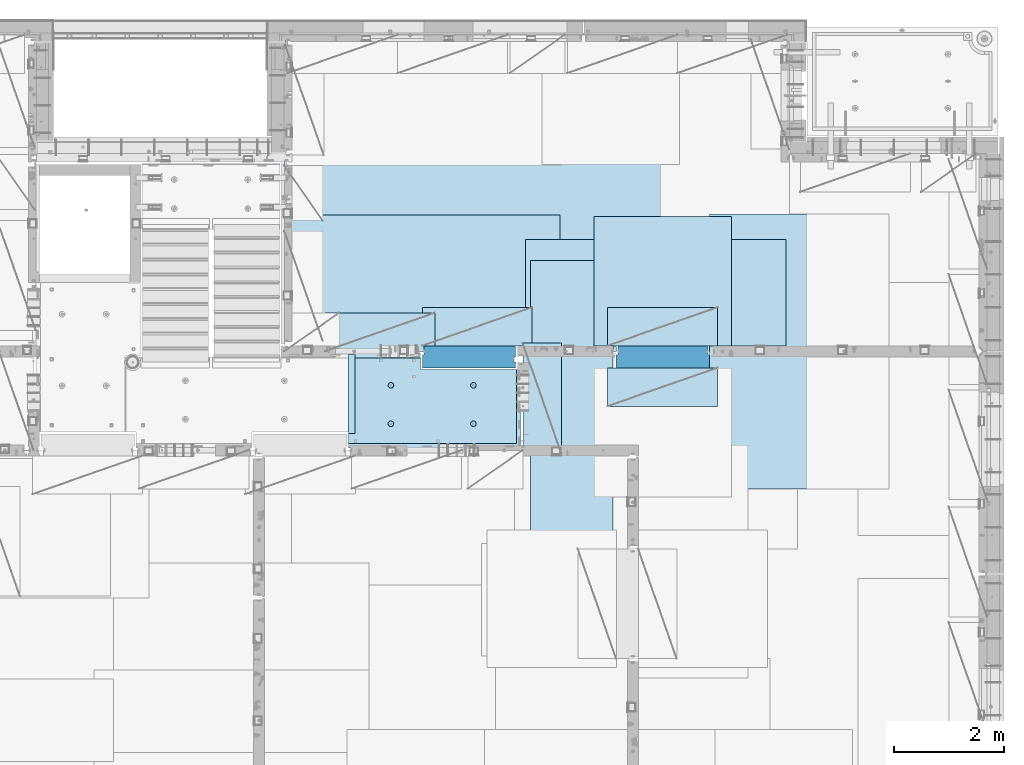
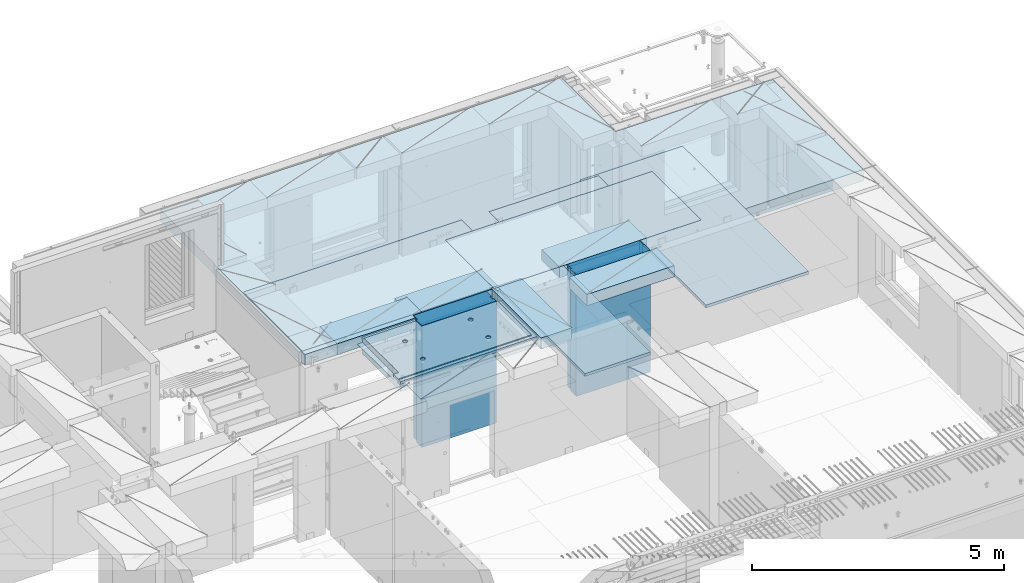
# One storey, part 210 of 350: 12 plates, 2 slabs, 13 elements without a shape of their own.
"""IFC2X3 building model written with IfcOpenShell, lengths in millimetres."""

from ifc_helpers import new_model, si_unit, frame, origin_with_axes, place, context, subcontext, project, spatial, faceted_brep, material, type_object, element, aggregate, save


model = new_model("IFC2X3")

# Units and contexts
model_context = context("Model", 3, precision=1e-05, world=origin_with_axes())
body_context = subcontext(model_context, "Body", "Model", "MODEL_VIEW")
ifc_project = project(units=[si_unit("LENGTHUNIT", "METRE", prefix="MILLI"), si_unit("AREAUNIT", "SQUARE_METRE"), si_unit("VOLUMEUNIT", "CUBIC_METRE"), si_unit("MASSUNIT", "GRAM", prefix="KILO"), si_unit("TIMEUNIT", "SECOND"), si_unit("PLANEANGLEUNIT", "RADIAN"), si_unit("SOLIDANGLEUNIT", "STERADIAN"), si_unit("THERMODYNAMICTEMPERATUREUNIT", "DEGREE_CELSIUS"), si_unit("LUMINOUSINTENSITYUNIT", "LUMEN")], contexts=[model_context])

# Site, building, storey
site_placement = place(None, origin_with_axes())
site = spatial("IfcSite", under=ifc_project, at=site_placement, CompositionType="ELEMENT")
building_placement = place(site_placement, origin_with_axes())
building = spatial("IfcBuilding", under=site, at=building_placement, CompositionType="ELEMENT")
storey_placement = place(building_placement, origin_with_axes())
storey = spatial("IfcBuildingStorey", under=building, at=storey_placement, Name="2", CompositionType="ELEMENT", Elevation=0.0)

# Assembly, slab
assembly_1_placement = place(storey_placement, origin_with_axes())
assembly_1 = element("IfcElementAssembly", 1, at=assembly_1_placement, inside=storey, AssemblyPlace="NOTDEFINED", PredefinedType="REINFORCEMENT_UNIT")
ifc_material_1 = material(Name="CONCRETE/C25/30")
slab_type_1 = type_object("IfcSlabType", PredefinedType="NOTDEFINED")
slab_1_placement = place(assembly_1_placement, frame((26570.0059390845, 15220.0026483125, 87620.0), z_axis=(-0.999999999997437, -2.26400000064461e-06, 0.0), x_axis=(-1.19799915409591e-06, 0.999999999999282, 0.0)))
slab_1 = element("IfcSlab", 2, at=slab_1_placement, type_object=slab_type_1, material=ifc_material_1, PredefinedType="FLOOR", context=body_context, shape_type="Brep", body=[
    faceted_brep([(260.000036693442, 30.0, 20.0001116859203), (260.00040878505, 30.0, 210.00282380305), (760.000392750888, 30.0, 210.001882803081), (760.000035167954, 30.0, 20.0003241859195), (259.999997532928, 50.0008466322761, 0.000110715616756352), (259.999997531775, 130.0, 4.72937244921923e-11), (260.00040878505, 130.0, 210.00282380305), (260.00003669344, 50.0008466322906, 20.0001116859239), (760.000392750888, 130.0, 210.001882803081), (759.999997530887, 50.0009701322706, 0.00188280345173553), (760.000035167954, 50.0009701322851, 20.0003241859267), (759.999997530887, 130.0, 1.4915713109076e-10), (0.0, 130.0, -1.81898940354586e-12), (0.0, 50.0007830199902, -3.63797880709171e-12), (2.23492861550767e-06, 50.0007830199902, 20.0000012144774), (0.00314200731554592, 50.0009709416772, 1679.99820316408), (0.00316042736994859, 130.0, 1679.99820316404), (20.0042037197236, 50.0007871208509, 20.0000019346335), (20.0050448999082, 50.0009732451872, 1679.9981655205), (20.0051981998968, 30.0, 1979.99816552074), (210.003723882246, 30.0, 1979.99780794351), (210.003159282247, 30.0, 1679.99780794404), (20.0050448999027, 30.0, 1679.9981655205), (20.0057858500695, 50.0011356208415, 3129.99855788155), (0.00588817475545511, 50.0011356208415, 3129.99536132812), (0.00371018100122456, 50.0010050132987, 1979.99820316354), (20.0051981998986, 50.0010068401461, 1979.99816552074), (1720.00727399273, -49.9988643791585, 3014.99216831216), (1700.0058891816, -49.9988643791585, 3014.99217713277), (1700.0058891816, 9.99999999994179, 3014.99217713277), (270.007273993393, 9.99999999994179, 3014.99280776216), (270.007273993393, -130.000000000058, 3014.99280776216), (1640.00591170533, -130.000000000058, 3014.99220359276), (1640.00591170533, -110.000000000058, 3014.99220359276), (1720.00727399273, -110.000000000058, 3014.99216831216), (1700.00578510373, 9.99999999994179, 3129.99536132812), (270.007324709519, 9.99999999994179, 3129.99536132812), (1700.00588013352, 9.99999999994179, 3024.99005271558), (270.007324709519, -130.0, 3129.99536132812), (0.0, -49.9992169800098, -3.63797880709171e-12), (1.81898940354586e-12, -110.000000000058, 0.0), (0.00588817475545511, -110.0, 3129.99536132812), (0.00588817475545511, -49.9988643791585, 3129.99536132812), (2.27349282795331e-05, -49.9992169800098, 20.000001214441), (40.0000000237706, -110.0, 0.00323799208854325), (40.0000056179106, -110.0, 80.000116817555), (80.0001648500238, -110.0, 80.0001140175445), (80.0058896111077, -110.0, 3129.99536132811), (80.0001648500238, -130.0, 80.0001140175445), (80.0058896111077, -130.0, 3129.99536132812), (458.262860973307, -110.000000000015, 813.90255309167), (472.201273869185, -110.000000000015, 821.004529187678), (483.262860973307, -110.000000000015, 832.066116291804), (490.364837069317, -110.000000000015, 846.004529187678), (492.812011254558, -110.000000000015, 861.455378906427), (490.364837069317, -110.000000000015, 876.906228625172), (483.262860973307, -110.000000000015, 890.844641521049), (472.201273869185, -110.000000000015, 901.906228625176), (458.262860973306, -110.000000000015, 909.008204721184), (442.81201125456, -110.000000000015, 911.455378906427), (427.361161535811, -110.000000000015, 909.008204721184), (413.422748639936, -110.000000000015, 901.906228625176), (402.361161535813, -110.000000000015, 890.844641521046), (395.259185439802, -110.000000000015, 876.906228625176), (392.81201125456, -110.000000000015, 861.455378906427), (395.259185439802, -110.000000000015, 846.004529187681), (402.361161535813, -110.000000000015, 832.0661162918), (413.422748639936, -110.000000000015, 821.004529187678), (427.361161535813, -110.000000000015, 813.90255309167), (442.812011254558, -110.000000000015, 811.455378906427), (458.965172324157, -130.0, 811.741061009179), (442.812011254558, -130.0, 809.182651633699), (473.537149442574, -130.0, 819.165854200462), (485.101535960521, -130.0, 830.730240718414), (492.526329151806, -130.0, 845.302217836826), (495.084738527285, -130.0, 861.45537890643), (492.526329151804, -130.0, 877.608539976027), (485.101535960521, -130.0, 892.180517094443), (473.537149442574, -130.0, 903.744903612387), (458.965172324157, -130.0, 911.16969680367), (442.81201125456, -130.0, 913.728106179151), (426.658850184962, -130.0, 911.169696803674), (412.086873066544, -130.0, 903.744903612391), (400.522486548598, -130.0, 892.180517094443), (393.097693357315, -130.0, 877.608539976027), (390.539283981834, -130.0, 861.455378906427), (393.097693357317, -130.0, 845.302217836826), (400.522486548598, -130.0, 830.730240718414), (412.086873066544, -130.0, 819.165854200462), (426.658850184962, -130.0, 811.741061009183), (1158.26361347154, -110.000000000058, 2313.90608356011), (1172.20202636741, -110.000000000058, 2321.00805965612), (1183.26361347154, -110.000000000058, 2332.06964676024), (1190.36558956755, -110.000000000058, 2346.00805965611), (1192.81276375279, -110.000000000058, 2361.45890937486), (1190.36558956755, -110.000000000058, 2376.90975909361), (1183.26361347154, -110.000000000058, 2390.84817198949), (1172.20202636741, -110.000000000058, 2401.90975909361), (1158.26361347154, -110.000000000058, 2409.01173518962), (1142.81276375279, -110.000000000058, 2411.45890937487), (1127.36191403404, -110.000000000058, 2409.01173518962), (1113.42350113817, -110.000000000058, 2401.90975909361), (1102.36191403404, -110.000000000058, 2390.84817198948), (1095.25993793803, -110.000000000058, 2376.90975909361), (1092.81276375279, -110.000000000058, 2361.45890937486), (1095.25993793803, -110.000000000058, 2346.00805965612), (1102.36191403404, -110.000000000058, 2332.06964676024), (1113.42350113817, -110.000000000058, 2321.00805965611), (1127.36191403405, -110.000000000058, 2313.90608356011), (1142.81276375279, -110.000000000058, 2311.45890937486), (1158.96592482239, -130.000000000044, 2311.74459147762), (1142.81276375279, -130.000000000044, 2309.18618210214), (1173.5379019408, -130.000000000044, 2319.1693846689), (1185.10228845875, -130.000000000044, 2330.73377118685), (1192.52708165004, -130.000000000044, 2345.30574830526), (1195.08549102551, -130.000000000044, 2361.45890937486), (1192.52708165004, -130.000000000044, 2377.61207044447), (1185.10228845875, -130.000000000044, 2392.18404756288), (1173.5379019408, -130.000000000044, 2403.74843408083), (1158.96592482239, -130.000000000044, 2411.17322727211), (1142.81276375279, -130.000000000044, 2413.73163664759), (1126.65960268319, -130.000000000044, 2411.17322727211), (1112.08762556478, -130.000000000044, 2403.74843408083), (1100.52323904683, -130.000000000044, 2392.18404756287), (1093.09844585554, -130.000000000044, 2377.61207044447), (1090.54003648007, -130.000000000044, 2361.45890937486), (1093.09844585555, -130.000000000044, 2345.30574830526), (1100.52323904683, -130.000000000044, 2330.73377118685), (1112.08762556478, -130.000000000044, 2319.1693846689), (1126.65960268319, -130.000000000044, 2311.74459147762), (1158.26322681425, -110.000000000029, 813.902566246979), (1172.20163971013, -110.000000000029, 821.004542342987), (1183.26322681425, -110.000000000029, 832.066129447114), (1190.36520291026, -110.000000000029, 846.004542342987), (1192.8123770955, -110.000000000029, 861.455392061736), (1190.36520291026, -110.000000000029, 876.906241780482), (1183.26322681425, -110.000000000029, 890.844654676363), (1172.20163971012, -110.000000000029, 901.906241780485), (1158.26322681425, -110.000000000029, 909.008217876493), (1142.8123770955, -110.000000000029, 911.455392061736), (1127.36152737675, -110.000000000029, 909.008217876493), (1113.42311448088, -110.000000000029, 901.906241780485), (1102.36152737675, -110.000000000029, 890.844654676359), (1095.25955128074, -110.000000000029, 876.906241780485), (1092.8123770955, -110.000000000029, 861.45539206174), (1095.25955128074, -110.000000000029, 846.004542342991), (1102.36152737675, -110.000000000029, 832.06612944711), (1113.42311448088, -110.000000000029, 821.004542342987), (1127.36152737675, -110.000000000029, 813.902566246979), (1142.8123770955, -110.000000000029, 811.455392061736), (1158.9655381651, -130.000000000029, 811.741074164489), (1142.8123770955, -130.000000000029, 809.182664789012), (1173.53751528352, -130.000000000029, 819.165867355772), (1185.10190180146, -130.000000000029, 830.730253873724), (1192.52669499275, -130.000000000029, 845.302230992136), (1195.08510436823, -130.000000000029, 861.45539206174), (1192.52669499275, -130.000000000029, 877.608553131337), (1185.10190180146, -130.000000000029, 892.180530249756), (1173.53751528351, -130.000000000029, 903.744916767697), (1158.9655381651, -130.000000000029, 911.16970995898), (1142.8123770955, -130.000000000029, 913.728119334461), (1126.6592160259, -130.000000000029, 911.169709958984), (1112.08723890749, -130.000000000029, 903.7449167677), (1100.52285238954, -130.000000000029, 892.180530249752), (1093.09805919825, -130.000000000029, 877.608553131337), (1090.53964982277, -130.000000000015, 861.455392061736), (1093.09805919826, -130.000000000015, 845.302230992136), (1100.52285238954, -130.000000000015, 830.730253873724), (1112.08723890749, -130.000000000015, 819.165867355776), (1126.6592160259, -130.000000000015, 811.741074164493), (458.263613472778, -110.000000000058, 2313.90740096011), (472.202026368655, -110.000000000058, 2321.00937705611), (483.263613472776, -110.000000000058, 2332.07096416024), (490.365589568788, -110.000000000058, 2346.00937705611), (492.812763754029, -110.000000000058, 2361.46022677486), (490.365589568788, -110.000000000058, 2376.91107649361), (483.263613472778, -110.000000000058, 2390.84948938949), (472.202026368655, -110.000000000058, 2401.91107649361), (458.263613472776, -110.000000000058, 2409.01305258962), (442.812763754029, -110.000000000058, 2411.46022677486), (427.361914035282, -110.000000000058, 2409.01305258962), (413.423501139407, -110.000000000058, 2401.91107649361), (402.361914035284, -110.000000000058, 2390.84948938949), (395.259937939272, -110.000000000058, 2376.91107649361), (392.812763754031, -110.000000000058, 2361.46022677486), (395.259937939272, -110.000000000058, 2346.00937705612), (402.361914035284, -110.000000000058, 2332.07096416024), (413.423501139407, -110.000000000058, 2321.00937705611), (427.361914035284, -110.000000000058, 2313.90740096011), (442.812763754029, -110.000000000058, 2311.46022677486), (458.965924823628, -130.000000000029, 2311.74590887762), (442.812763754029, -130.000000000029, 2309.18749950214), (473.537901942043, -130.000000000029, 2319.1707020689), (485.10228845999, -130.000000000029, 2330.73508858685), (492.527081651273, -130.000000000029, 2345.30706570526), (495.085491026754, -130.000000000029, 2361.46022677486), (492.527081651273, -130.000000000029, 2377.61338784446), (485.102288459992, -130.000000000029, 2392.18536496288), (473.537901942043, -130.000000000029, 2403.74975148082), (458.965924823628, -130.000000000029, 2411.1745446721), (442.812763754031, -130.000000000029, 2413.73295404758), (426.659602684433, -130.000000000029, 2411.17454467211), (412.087625566017, -130.000000000029, 2403.74975148082), (400.523239048071, -130.000000000029, 2392.18536496288), (393.098445856787, -130.000000000029, 2377.61338784446), (390.540036481307, -130.000000000029, 2361.46022677486), (393.098445856789, -130.000000000029, 2345.30706570526), (400.523239048067, -130.000000000029, 2330.73508858685), (412.087625566017, -130.000000000029, 2319.17070206891), (426.659602684433, -130.000000000029, 2311.74590887762), (1640.0069692709, -130.000000000058, 1820.00285259458), (1429.99412576448, -130.0, 80.0005450159842), (1430.00077693619, -130.000000000044, 1820.00324782623), (1640.0069692709, -110.000000000058, 1820.00285259458), (1720.00719314726, -110.000000000058, 1820.00270203416), (1720.00719416424, -49.9988643791585, 1820.00270203415), (1700.00697064704, -49.9988643791585, 1820.00273967458), (1430.00077693619, 129.999999999985, 1820.00324782623), (1720.00507313573, 130.0, 1820.00270203815), (1720.00696350816, 50.0011356208415, 1820.00270203459), (1700.00697064704, 50.0011356208415, 1820.00273967458), (1720.00548380367, 130.0, 2629.9953613439), (1720.00479630696, 50.0011356208415, 2629.99536134425), (1700.00623760369, 50.0011356208415, 2629.99539898154), (1700.00623760369, 30.0, 2629.99539898154), (1700.00578510373, 30.0, 3129.99535793147), (1510.00479630733, 130.0, 2629.99575656425), (1510.00479630733, 30.0, 2629.99575656425), (1510.00573730659, 130.0, 3129.99536132812), (1510.00573730659, 30.0, 3129.99536134176), (0.00588817475545511, 130.0, 3129.99536132812), (20.0057858500695, -49.9988643791585, 3129.99855788155), (0.00372479000361636, 130.0, 1979.99820316351), (210.003723882246, 130.0, 1979.99780794351), (210.003159282247, 130.0, 1679.99780794404), (20.0042037196527, -49.9988643791585, 20.0000019345935), (20.0041864226587, -49.9992128791491, 7.34271452529356e-07), (1429.99419217423, -49.9988643791585, 20.0006089333838), (1429.99420067423, -49.9988643791585, 0.000608933383773547), (80.0000146155362, -110.0, 0.000114017555461032), (1429.99735169022, -110.0, 7.40013310860377e-05), (1429.99412576448, -110.0, 80.0005450159842), (1429.99416747423, 50.0011356208415, 20.0006089334311), (1429.99417597423, 50.0011356208415, 0.000608933431067271), (1429.99735169022, 130.0, 2.80124368146062e-10), (20.0041864225386, 50.0007871208509, -3.03407432511449e-09)], [[[0, 1, 2, 3]], [[4, 5, 6, 1, 0, 7]], [[8, 2, 1, 6]], [[9, 10, 3, 2, 8, 11]], [[12, 13, 14, 15, 16]], [[14, 17, 18, 15]], [[19, 20, 21, 22]], [[23, 24, 25, 26]], [[27, 28, 29, 30, 31, 32, 33, 34]], [[35, 36, 30, 29, 37]], [[31, 30, 36, 38]], [[39, 40, 41, 42, 43]], [[44, 45, 46, 47, 41, 40]], [[48, 49, 47, 46]], [[50, 51, 52, 53, 54, 55, 56, 57, 58, 59, 60, 61, 62, 63, 64, 65, 66, 67, 68, 69]], [[70, 50, 69, 71]], [[72, 51, 50, 70]], [[73, 52, 51, 72]], [[74, 53, 52, 73]], [[75, 54, 53, 74]], [[76, 55, 54, 75]], [[77, 56, 55, 76]], [[78, 57, 56, 77]], [[79, 58, 57, 78]], [[80, 59, 58, 79]], [[81, 60, 59, 80]], [[82, 61, 60, 81]], [[83, 62, 61, 82]], [[84, 63, 62, 83]], [[85, 64, 63, 84]], [[86, 65, 64, 85]], [[87, 66, 65, 86]], [[88, 67, 66, 87]], [[89, 68, 67, 88]], [[71, 69, 68, 89]], [[90, 91, 92, 93, 94, 95, 96, 97, 98, 99, 100, 101, 102, 103, 104, 105, 106, 107, 108, 109]], [[110, 90, 109, 111]], [[112, 91, 90, 110]], [[113, 92, 91, 112]], [[114, 93, 92, 113]], [[115, 94, 93, 114]], [[116, 95, 94, 115]], [[117, 96, 95, 116]], [[118, 97, 96, 117]], [[119, 98, 97, 118]], [[120, 99, 98, 119]], [[121, 100, 99, 120]], [[122, 101, 100, 121]], [[123, 102, 101, 122]], [[124, 103, 102, 123]], [[125, 104, 103, 124]], [[126, 105, 104, 125]], [[127, 106, 105, 126]], [[128, 107, 106, 127]], [[129, 108, 107, 128]], [[111, 109, 108, 129]], [[130, 131, 132, 133, 134, 135, 136, 137, 138, 139, 140, 141, 142, 143, 144, 145, 146, 147, 148, 149]], [[150, 130, 149, 151]], [[152, 131, 130, 150]], [[153, 132, 131, 152]], [[154, 133, 132, 153]], [[155, 134, 133, 154]], [[156, 135, 134, 155]], [[157, 136, 135, 156]], [[158, 137, 136, 157]], [[159, 138, 137, 158]], [[160, 139, 138, 159]], [[161, 140, 139, 160]], [[162, 141, 140, 161]], [[163, 142, 141, 162]], [[164, 143, 142, 163]], [[165, 144, 143, 164]], [[166, 145, 144, 165]], [[167, 146, 145, 166]], [[168, 147, 146, 167]], [[169, 148, 147, 168]], [[151, 149, 148, 169]], [[170, 171, 172, 173, 174, 175, 176, 177, 178, 179, 180, 181, 182, 183, 184, 185, 186, 187, 188, 189]], [[190, 170, 189, 191]], [[192, 171, 170, 190]], [[193, 172, 171, 192]], [[194, 173, 172, 193]], [[195, 174, 173, 194]], [[196, 175, 174, 195]], [[197, 176, 175, 196]], [[198, 177, 176, 197]], [[199, 178, 177, 198]], [[200, 179, 178, 199]], [[201, 180, 179, 200]], [[202, 181, 180, 201]], [[203, 182, 181, 202]], [[204, 183, 182, 203]], [[205, 184, 183, 204]], [[206, 185, 184, 205]], [[207, 186, 185, 206]], [[208, 187, 186, 207]], [[209, 188, 187, 208]], [[191, 189, 188, 209]], [[210, 32, 31, 38, 49, 48, 211, 212], [208, 207, 206, 205, 204, 203, 202, 201, 200, 199, 198, 197, 196, 195, 194, 193, 192, 190, 191, 209], [168, 167, 166, 165, 164, 163, 162, 161, 160, 159, 158, 157, 156, 155, 154, 153, 152, 150, 151, 169], [128, 127, 126, 125, 124, 123, 122, 121, 120, 119, 118, 117, 116, 115, 114, 113, 112, 110, 111, 129], [88, 87, 86, 85, 84, 83, 82, 81, 80, 79, 78, 77, 76, 75, 74, 73, 72, 70, 71, 89]], [[33, 32, 210, 213]], [[34, 33, 213, 214]], [[27, 34, 214, 215]], [[28, 27, 215, 216]], [[214, 213, 210, 212, 217, 218, 219, 220, 216, 215]], [[219, 218, 221, 222]], [[220, 219, 222, 223]], [[35, 37, 29, 28, 216, 220, 223, 224, 225]], [[222, 221, 226, 227, 224, 223]], [[228, 229, 227, 226]], [[224, 227, 229, 225]], [[228, 230, 24, 23, 231, 42, 41, 47, 49, 38, 36, 35, 225, 229]], [[24, 230, 232, 25]], [[233, 20, 19, 26, 25, 232]], [[234, 21, 20, 233]], [[16, 15, 18, 22, 21, 234]], [[17, 235, 231, 23, 26, 19, 22, 18]], [[43, 42, 231, 235]], [[236, 39, 43, 235, 237, 238]], [[239, 44, 40, 39, 236, 238, 240]], [[46, 45, 44, 239, 240, 241]], [[48, 46, 241, 211]], [[240, 238, 237, 242, 243, 244, 217, 212, 211, 241]], [[244, 243, 9, 11]], [[6, 5, 12, 16, 234, 233, 232, 230, 228, 226, 221, 218, 217, 244, 11, 8]], [[245, 13, 12, 5, 4]], [[17, 14, 13, 245, 4, 7]], [[242, 237, 235, 17, 7, 0, 3, 10]], [[243, 242, 10, 9]]]),
])
aggregate(assembly_1, [slab_1])

assembly_2_placement = place(storey_placement, origin_with_axes())
assembly_2 = element("IfcElementAssembly", 3, at=assembly_2_placement, inside=storey, AssemblyPlace="NOTDEFINED", PredefinedType="REINFORCEMENT_UNIT")
ifc_material_2 = material(Name="CONCRETE/C30/37")
slab_type_2 = type_object("IfcSlabType", PredefinedType="NOTDEFINED")
slab_2_placement = place(assembly_2_placement, frame((22310.0, 16980.0, 87595.0), z_axis=(0.0, 1.0, 0.0), x_axis=(1.0, 0.0, 0.0)))
slab_2 = element("IfcSlab", 4, at=slab_2_placement, type_object=slab_type_2, material=ifc_material_2, PredefinedType="FLOOR", context=body_context, shape_type="Brep", body=[
    faceted_brep([(4369.99914550782, -135.0, 99.9999987875526), (4369.99914550782, 135.0, 99.9999987875526), (4369.99914550782, 135.0, 0.0), (4369.99914550782, -135.0, 0.0), (4169.99914550781, -135.0, 99.9997253417969), (4169.99914550781, 135.0, 99.9997253417969), (2489.99914550781, -135.0, 0.0), (2489.99914550781, 135.0, 0.0), (2489.99914550781, 135.0, 99.9997253417969), (2489.99914550781, -135.0, 99.9997253417969), (1.81898940354586e-12, -135.0, 1.81898940354586e-12), (1.81898940354586e-12, 135.0, 1.81898940354586e-12), (-39.9985427856445, -135.0, -0.0037095642182976), (-39.9985427856445, 135.0, -0.0037095642182976), (-40.0, -135.0, 3600.00048828125), (-40.0, 135.0, 3600.00048828125), (-20.0, -135.0, 3600.0), (-20.0, 135.0, 3600.0), (-20.0, -135.0, 5760.0), (-20.0, 135.0, 5760.0), (9149.9990234375, -135.0, 5760.0), (9149.9990234375, 135.0, 5760.0), (9149.9990234375, -135.0, 3600.00073242188), (9149.9990234375, 135.0, 3600.00073242188), (12750.0, -135.0, 3599.9951171875), (12750.0, 135.0, 3599.9951171875), (12750.0, -135.0, 0.0), (12750.0, 135.0, 0.0), (7685.0006429507, -135.0, 0.0), (7685.0006429507, 135.0, 0.0), (7685.0006429507, -135.0, 99.9996630941932), (7685.0006429507, 135.0, 99.9996630941932), (5999.99954431789, -135.0, 99.9996630941932), (5999.99954431789, 135.0, 99.9996630941932), (5999.99954431789, -135.0, 0.0), (5999.99954431789, 135.0, 0.0), (2730.00000000001, 135.0, 99.9997253417969), (2730.00000000001, -135.0, 99.9997253417969)], [[[0, 1, 2, 3]], [[4, 5, 1, 0]], [[6, 7, 8, 9]], [[10, 11, 7, 6]], [[10, 12, 13, 11]], [[12, 14, 15, 13]], [[14, 16, 17, 15]], [[16, 18, 19, 17]], [[18, 20, 21, 19]], [[20, 22, 23, 21]], [[22, 24, 25, 23]], [[24, 26, 27, 25]], [[27, 26, 28, 29]], [[30, 31, 29, 28]], [[32, 33, 31, 30]], [[34, 35, 33, 32]], [[35, 34, 3, 2]], [[36, 8, 7, 11, 13, 15, 17, 19, 21, 23, 25, 27, 29, 31, 33, 35, 2, 1, 5]], [[37, 9, 8, 36, 5, 4]], [[34, 32, 30, 28, 26, 24, 22, 20, 18, 16, 14, 12, 10, 6, 9, 37, 4, 0, 3]]]),
])

# Assembly, plate
assembly_3_placement = place(storey_placement, origin_with_axes())
assembly_3 = element("IfcElementAssembly", 5, at=assembly_3_placement, inside=storey, Name="Steel Assembly", AssemblyPlace="NOTDEFINED", PredefinedType="NOTDEFINED")
ifc_material_3 = material()
plate_type_1 = type_object("IfcPlateType", PredefinedType="NOTDEFINED")
plate_1_placement = place(assembly_3_placement, frame((22289.9998779297, 19460.0009765625, 87695.1), z_axis=(1.0, 0.0, 0.0), x_axis=(0.0, -1.0, 0.0)))
plate_1 = element("IfcPlate", 6, at=plate_1_placement, type_object=plate_type_1, material=ifc_material_3, context=body_context, shape_type="Brep", body=[
    faceted_brep([(0.0, -35.0, 0.0), (0.0, -35.0, 5000.0), (0.0, 35.0, 5000.0), (0.0, 35.0, 0.0), (2349.99951171875, -35.0, 5000.0), (2349.99951171875, 35.0, 5000.0), (2350.0, -35.0, 0.0), (2350.0, 35.0, 0.0)], [[[0, 1, 2, 3]], [[1, 4, 5, 2]], [[4, 6, 7, 5]], [[6, 0, 3, 7]], [[5, 7, 3, 2]], [[6, 4, 1, 0]]]),
])
aggregate(assembly_3, [plate_1])

assembly_4_placement = place(storey_placement, origin_with_axes())
assembly_4 = element("IfcElementAssembly", 7, at=assembly_4_placement, inside=storey, Name="Steel Assembly", AssemblyPlace="NOTDEFINED", PredefinedType="NOTDEFINED")
plate_2_placement = place(assembly_4_placement, frame((27902.5, 19430.0, 87695.1), z_axis=(1.0, 0.0, 0.0), x_axis=(0.0, -1.0, 0.0)))
plate_2 = element("IfcPlate", 8, at=plate_2_placement, type_object=plate_type_1, material=ifc_material_3, Name="1/2", context=body_context, shape_type="Brep", body=[
    faceted_brep([(0.0, -35.0, 0.0), (0.0, -35.0, 2500.0), (0.0, 35.0, 2500.0), (0.0, 35.0, 0.0), (2349.99951171875, -35.0, 2500.0), (2349.99951171875, 35.0, 2500.0), (2350.0, -35.0, 0.0), (2350.0, 35.0, 0.0)], [[[0, 1, 2, 3]], [[1, 4, 5, 2]], [[4, 6, 7, 5]], [[6, 0, 3, 7]], [[5, 7, 3, 2]], [[6, 4, 1, 0]]]),
])
aggregate(assembly_4, [plate_2])

assembly_5_placement = place(storey_placement, origin_with_axes())
assembly_5 = element("IfcElementAssembly", 9, at=assembly_5_placement, inside=storey, Name="Steel Assembly", AssemblyPlace="NOTDEFINED", PredefinedType="NOTDEFINED")
plate_3_placement = place(assembly_5_placement, frame((32360.0, 19480.0, 87695.1), z_axis=(0.0, -1.0, 0.0), x_axis=(-1.0, 3.00000001838171e-08, 0.0)))
plate_3 = element("IfcPlate", 10, at=plate_3_placement, type_object=plate_type_1, material=ifc_material_3, context=body_context, shape_type="Brep", body=[
    faceted_brep([(0.0, -35.0, 0.0), (0.0, -35.0, 5000.0), (0.0, 35.0, 5000.0), (0.0, 35.0, 0.0), (2349.99951171875, -35.0, 5000.0), (2349.99951171875, 35.0, 5000.0), (2350.0, -35.0, 0.0), (2350.0, 35.0, 0.0)], [[[0, 1, 2, 3]], [[1, 4, 5, 2]], [[4, 6, 7, 5]], [[6, 0, 3, 7]], [[5, 7, 3, 2]], [[6, 4, 1, 0]]]),
])
aggregate(assembly_5, [plate_3])

assembly_6_placement = place(storey_placement, origin_with_axes())
assembly_6 = element("IfcElementAssembly", 11, at=assembly_6_placement, inside=storey, Name="Steel Assembly", AssemblyPlace="NOTDEFINED", PredefinedType="NOTDEFINED")
plate_type_2 = type_object("IfcPlateType", PredefinedType="NOTDEFINED")
plate_4_placement = place(assembly_6_placement, frame((28250.0000122641, 18630.0, 87695.1000003815), z_axis=(0.0, -1.0, 0.0), x_axis=(-1.0, 3.00000001838171e-08, 0.0)))
plate_4 = element("IfcPlate", 12, at=plate_4_placement, type_object=plate_type_2, material=ifc_material_3, context=body_context, shape_type="Brep", body=[
    faceted_brep([(0.0, -35.0, 0.0), (0.0, -35.0, 5000.0), (0.0, 35.0, 5000.0), (0.0, 35.0, 0.0), (1499.99951171875, -35.0, 5000.0), (1499.99951171875, 35.0, 5000.0), (1500.0, -35.0, 0.0), (1500.0, 35.0, 0.0)], [[[0, 1, 2, 3]], [[1, 4, 5, 2]], [[4, 6, 7, 5]], [[6, 0, 3, 7]], [[5, 7, 3, 2]], [[6, 4, 1, 0]]]),
])
aggregate(assembly_6, [plate_4])

assembly_7_placement = place(storey_placement, origin_with_axes())
assembly_7 = element("IfcElementAssembly", 13, at=assembly_7_placement, inside=storey, Name="Steel Assembly", AssemblyPlace="NOTDEFINED", PredefinedType="NOTDEFINED")
plate_type_3 = type_object("IfcPlateType", PredefinedType="NOTDEFINED")
plate_5_placement = place(assembly_7_placement, frame((23010.0008542386, 16980.0001036336, 87595.3), z_axis=(0.0, 1.0, 0.0), x_axis=(1.0, 0.0, 0.0)))
plate_5 = element("IfcPlate", 14, at=plate_5_placement, type_object=plate_type_3, material=ifc_material_3, Name="RE1", context=body_context, shape_type="Brep", body=[
    faceted_brep([(1.81898940354586e-12, -135.0, 1.81898940354586e-12), (0.0, -135.0, 699.999999999996), (0.0, 135.0, 699.999999999996), (1.81898940354586e-12, 135.0, 1.81898940354586e-12), (1999.99951171875, -135.0, 699.999999999993), (1999.99951171875, 135.0, 699.999999999993), (2000.0, -135.0, -3.63797880709171e-12), (2000.0, 135.0, -3.63797880709171e-12)], [[[0, 1, 2, 3]], [[1, 4, 5, 2]], [[4, 6, 7, 5]], [[6, 0, 3, 7]], [[5, 7, 3, 2]], [[6, 4, 1, 0]]]),
])
aggregate(assembly_7, [plate_5])

assembly_8_placement = place(storey_placement, origin_with_axes())
assembly_8 = element("IfcElementAssembly", 15, at=assembly_8_placement, inside=storey, Name="Steel Assembly", AssemblyPlace="NOTDEFINED", PredefinedType="NOTDEFINED")
plate_6_placement = place(assembly_8_placement, frame((30152.4991457614, 16679.9998963664, 87595.3), z_axis=(0.0, -1.0, 0.0), x_axis=(-1.0, 3.00000001838171e-08, 0.0)))
plate_6 = element("IfcPlate", 16, at=plate_6_placement, type_object=plate_type_3, material=ifc_material_3, Name="RE1", context=body_context, shape_type="Brep", body=[
    faceted_brep([(1.81898940354586e-12, -135.0, 1.81898940354586e-12), (0.0, -135.0, 699.999999999996), (0.0, 135.0, 699.999999999996), (1.81898940354586e-12, 135.0, 1.81898940354586e-12), (1999.99951171875, -135.0, 699.999999999993), (1999.99951171875, 135.0, 699.999999999993), (2000.0, -135.0, -3.63797880709171e-12), (2000.0, 135.0, -3.63797880709171e-12)], [[[0, 1, 2, 3]], [[1, 4, 5, 2]], [[4, 6, 7, 5]], [[6, 0, 3, 7]], [[5, 7, 3, 2]], [[6, 4, 1, 0]]]),
])
aggregate(assembly_8, [plate_6])

assembly_9_placement = place(storey_placement, origin_with_axes())
assembly_9 = element("IfcElementAssembly", 17, at=assembly_9_placement, inside=storey, Name="Steel Assembly", AssemblyPlace="NOTDEFINED", PredefinedType="NOTDEFINED")
plate_7_placement = place(assembly_9_placement, frame((28152.5008542386, 17080.0001036336, 87595.3), z_axis=(0.0, 1.0, 0.0), x_axis=(1.0, 0.0, 0.0)))
plate_7 = element("IfcPlate", 18, at=plate_7_placement, type_object=plate_type_3, material=ifc_material_3, Name="RE1", context=body_context, shape_type="Brep", body=[
    faceted_brep([(1.81898940354586e-12, -135.0, 1.81898940354586e-12), (0.0, -135.0, 699.999999999996), (0.0, 135.0, 699.999999999996), (1.81898940354586e-12, 135.0, 1.81898940354586e-12), (1999.99951171875, -135.0, 699.999999999993), (1999.99951171875, 135.0, 699.999999999993), (2000.0, -135.0, -3.63797880709171e-12), (2000.0, 135.0, -3.63797880709171e-12)], [[[0, 1, 2, 3]], [[1, 4, 5, 2]], [[4, 6, 7, 5]], [[6, 0, 3, 7]], [[5, 7, 3, 2]], [[6, 4, 1, 0]]]),
])
aggregate(assembly_9, [plate_7])

assembly_10_placement = place(storey_placement, origin_with_axes())
assembly_10 = element("IfcElementAssembly", 19, at=assembly_10_placement, inside=storey, Name="Steel Assembly", AssemblyPlace="NOTDEFINED", PredefinedType="NOTDEFINED")
plate_8_placement = place(assembly_10_placement, frame((24780.0008542386, 17080.0001036336, 87595.3), z_axis=(0.0, 1.0, 0.0), x_axis=(1.0, 0.0, 0.0)))
plate_8 = element("IfcPlate", 20, at=plate_8_placement, type_object=plate_type_3, material=ifc_material_3, Name="RE1", context=body_context, shape_type="Brep", body=[
    faceted_brep([(1.81898940354586e-12, -135.0, 1.81898940354586e-12), (0.0, -135.0, 699.999999999996), (0.0, 135.0, 699.999999999996), (1.81898940354586e-12, 135.0, 1.81898940354586e-12), (1999.99951171875, -135.0, 699.999999999993), (1999.99951171875, 135.0, 699.999999999993), (2000.0, -135.0, -3.63797880709171e-12), (2000.0, 135.0, -3.63797880709171e-12)], [[[0, 1, 2, 3]], [[1, 4, 5, 2]], [[4, 6, 7, 5]], [[6, 0, 3, 7]], [[5, 7, 3, 2]], [[6, 4, 1, 0]]]),
])
aggregate(assembly_10, [plate_8])

assembly_11_placement = place(storey_placement, origin_with_axes())
assembly_11 = element("IfcElementAssembly", 21, at=assembly_11_placement, inside=storey, Name="Steel Assembly", AssemblyPlace="NOTDEFINED", PredefinedType="NOTDEFINED")
plate_9_placement = place(assembly_11_placement, frame((26609.9998779297, 17130.0, 87595.3), z_axis=(1.0, 0.0, 0.0), x_axis=(0.0, -1.0, 0.0)))
plate_9 = element("IfcPlate", 22, at=plate_9_placement, type_object=plate_type_3, material=ifc_material_3, Name="RE1", context=body_context, shape_type="Brep", body=[
    faceted_brep([(1.81898940354586e-12, -135.0, 1.81898940354586e-12), (0.0, -135.0, 699.999999999996), (0.0, 135.0, 699.999999999996), (1.81898940354586e-12, 135.0, 1.81898940354586e-12), (1999.99951171875, -135.0, 699.999999999993), (1999.99951171875, 135.0, 699.999999999993), (2000.0, -135.0, -3.63797880709171e-12), (2000.0, 135.0, -3.63797880709171e-12)], [[[0, 1, 2, 3]], [[1, 4, 5, 2]], [[4, 6, 7, 5]], [[6, 0, 3, 7]], [[5, 7, 3, 2]], [[6, 4, 1, 0]]]),
])
aggregate(assembly_11, [plate_9])

# Plate
plate_type_4 = type_object("IfcPlateType", PredefinedType="NOTDEFINED")
plate_10_placement = place(assembly_2_placement, frame((31402.0004441066, 19019.9993561238, 87725.45), z_axis=(0.0, -1.0, 0.0), x_axis=(-1.0, 3.00000001838171e-08, 0.0)))
plate_10 = element("IfcPlate", 23, at=plate_10_placement, type_object=plate_type_4, material=ifc_material_3, context=body_context, shape_type="Brep", body=[
    faceted_brep([(0.0, -5.0, 0.0), (0.0, -5.0, 1939.99963378906), (0.0, 5.0, 1939.99963378906), (0.0, 5.0, 0.0), (4742.00048828125, -5.0, 1939.99963378906), (4742.00048828125, 5.0, 1939.99963378906), (4742.00048828125, -5.0, 0.0), (4742.00048828125, 5.0, 0.0), (92.0009613037109, -5.0, 0.0), (92.0009613037109, 5.0, 0.0)], [[[0, 1, 2, 3]], [[1, 4, 5, 2]], [[4, 6, 7, 5]], [[6, 8, 9, 7]], [[8, 0, 3, 9]], [[5, 7, 9, 3, 2]], [[8, 6, 4, 1, 0]]]),
])

aggregate(assembly_2, [plate_10, slab_2])

# Assembly, plate
assembly_12_placement = place(storey_placement, origin_with_axes())
assembly_12 = element("IfcElementAssembly", 24, at=assembly_12_placement, inside=storey, Name="Steel Assembly", AssemblyPlace="NOTDEFINED", PredefinedType="NOTDEFINED")
ifc_material_4 = material()
plate_type_5 = type_object("IfcPlateType", PredefinedType="NOTDEFINED")
plate_11_placement = place(assembly_12_placement, frame((24780.0, 16680.0, 86255.6000003815), z_axis=(0.0, 1.0, 0.0), x_axis=(1.0, 0.0, 0.0)))
plate_11 = element("IfcPlate", 25, at=plate_11_placement, type_object=plate_type_5, material=ifc_material_4, context=body_context, shape_type="Brep", body=[
    faceted_brep([(1699.99914550781, -1475.0, 110.0), (1699.99914550781, 1475.0, 110.0), (1669.99914550781, 1475.0, 110.0), (1669.99914550781, -1475.00000000001, 110.0), (1669.99914550781, 1475.0, 200.0), (1669.99914550781, -1475.00000000001, 200.0), (1699.99914550781, -1475.0, 200.0), (1699.99914550781, 1475.0, 200.0), (1699.99914550781, -1475.0, 3.63797880709171e-12), (0.0, -1475.0, 0.0), (0.0, 1475.0, 0.0), (1699.99914550781, 1475.0, 3.63797880709171e-12), (0.0, -1475.0, 230.0), (0.0, 1475.0, 230.0), (30.0, -1475.0, 243.0), (30.0, 1475.0, 243.0), (30.0, -1475.0, 400.0), (30.0, 1475.0, 400.0), (1699.99914550781, -1475.0, 400.0), (1699.99914550781, 1475.0, 400.0)], [[[0, 1, 2, 3]], [[3, 2, 4, 5]], [[6, 5, 4, 7]], [[8, 9, 10, 11]], [[10, 9, 12, 13]], [[14, 15, 13, 12]], [[16, 17, 15, 14]], [[18, 19, 17, 16]], [[19, 18, 6, 7]], [[2, 1, 11, 10, 13, 15, 17, 19, 7, 4]], [[8, 11, 1, 0]], [[18, 16, 14, 12, 9, 8, 0, 3, 5, 6]]]),
])
aggregate(assembly_12, [plate_11])

assembly_13_placement = place(storey_placement, origin_with_axes())
assembly_13 = element("IfcElementAssembly", 26, at=assembly_13_placement, inside=storey, Name="Steel Assembly", AssemblyPlace="NOTDEFINED", PredefinedType="NOTDEFINED")
plate_12_placement = place(assembly_13_placement, frame((28309.9999105288, 16680.0000293051, 86255.6000003815), z_axis=(0.0, 1.0, 0.0), x_axis=(1.0, 0.0, 0.0)))
plate_12 = element("IfcPlate", 27, at=plate_12_placement, type_object=plate_type_5, material=ifc_material_4, context=body_context, shape_type="Brep", body=[
    faceted_brep([(29.9999989126591, -1475.0, 243.000885767418), (29.9999989126591, 1475.0, 243.000885767418), (0.0, 1475.0, 230.000886222213), (0.0, -1475.0, 230.000886222213), (30.0000025741901, -1475.0, 399.999635204884), (30.0000025741901, 1475.0, 399.999633789063), (1700.00073242188, -1475.0, 0.0), (0.0, -1475.0, 0.0), (0.0, 1475.0, 0.0), (1700.00073242188, 1475.0, 0.0), (1700.00073242188, 1475.0, 230.001129150391), (1700.00041094652, -1475.0, 230.001129150391), (1670.00041094652, 1475.0, 243.001129150391), (1670.00041094652, -1475.0, 243.001129150391), (1670.00041094652, -1475.0, 399.999633789063), (1670.00041094652, 1475.0, 399.999633789063)], [[[0, 1, 2, 3]], [[4, 5, 1, 0]], [[6, 7, 8, 9]], [[6, 9, 10, 11]], [[11, 10, 12, 13]], [[14, 13, 12, 15]], [[3, 7, 6, 11, 13, 14, 4, 0]], [[8, 7, 3, 2]], [[15, 12, 10, 9, 8, 2, 1, 5]], [[14, 15, 5, 4]]]),
])
aggregate(assembly_13, [plate_12])

save(model, "model.ifc")
